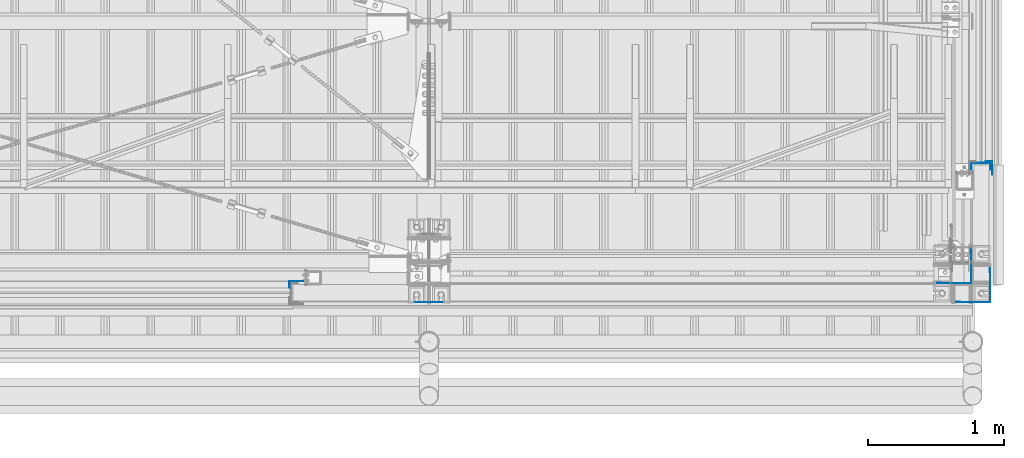
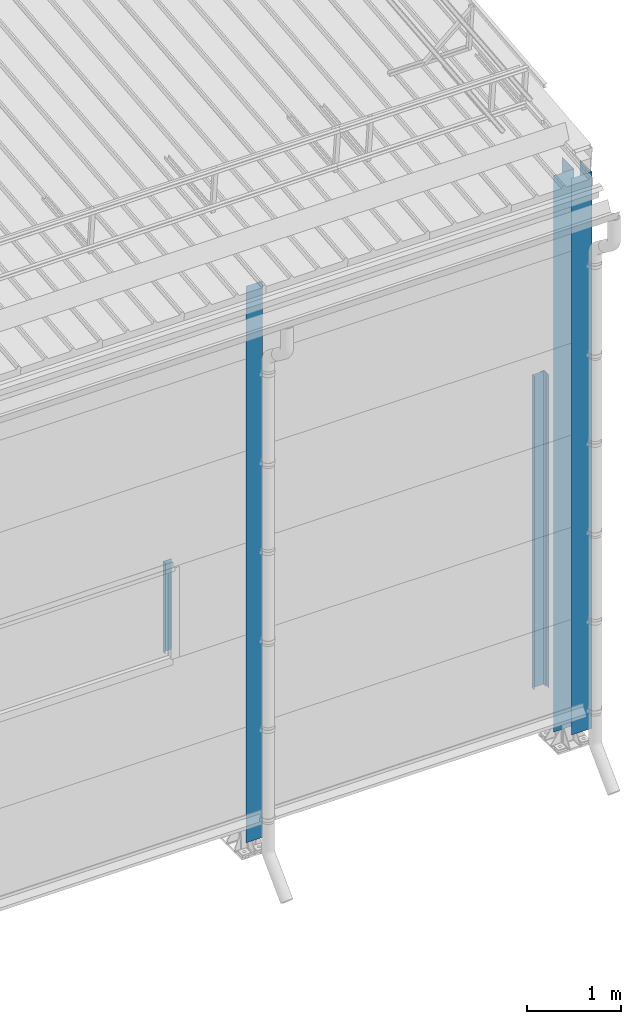
# One storey, part 12 of 709: 6 columns, 6 elements without a shape of their own.
"""IFC4 building model written with IfcOpenShell, lengths in millimetres."""

from ifc_helpers import new_model, si_unit, direction, frame, origin_with_axes, place, context, subcontext, project, spatial, line, indexed_curve, outline, extrude, material, element, aggregate, save


model = new_model("IFC4")

# Units and contexts
model_context = context("Model", 3, precision=0.2, world=origin_with_axes(), true_north=direction((0.0, 1.0)))
body_context = subcontext(model_context, "Body", "Model", "MODEL_VIEW")
ifc_project = project(units=[si_unit("LENGTHUNIT", "METRE", prefix="MILLI"), si_unit("AREAUNIT", "SQUARE_METRE"), si_unit("VOLUMEUNIT", "CUBIC_METRE"), si_unit("MASSUNIT", "GRAM", prefix="KILO"), si_unit("TIMEUNIT", "SECOND"), si_unit("PLANEANGLEUNIT", "RADIAN"), si_unit("SOLIDANGLEUNIT", "STERADIAN"), si_unit("THERMODYNAMICTEMPERATUREUNIT", "DEGREE_CELSIUS"), si_unit("LUMINOUSINTENSITYUNIT", "LUMEN")], contexts=[model_context])

# Site, building, storey
site_placement = place(None, origin_with_axes())
site = spatial("IfcSite", under=ifc_project, at=site_placement, CompositionType="ELEMENT")
building_placement = place(site_placement, origin_with_axes())
building = spatial("IfcBuilding", under=site, at=building_placement, Name="Undefined", CompositionType="ELEMENT")
storey_placement = place(building_placement, origin_with_axes())
storey = spatial("IfcBuildingStorey", under=building, at=storey_placement, Name="Undefined", CompositionType="ELEMENT", Elevation=0.0)

# Assembly, column
assembly_1_placement = place(storey_placement, frame((44975.0, 1.0, 2700.0), z_axis=(0.0, 1.0, 0.0), x_axis=(0.0, 0.0, 1.0)))
assembly_1 = element("IfcElementAssembly", 1, at=assembly_1_placement, inside=storey)
ifc_material = material(Name="Steel_Undefined", Category="STEEL")
column_1_placement = place(assembly_1_placement, origin_with_axes())
column_1 = element("IfcColumn", 2, at=column_1_placement, material=ifc_material, context=body_context, shape_type="SolidModel", body=[
    extrude(outline(indexed_curve([(-25.0, -1.0), (25.0, -1.0), (25.0, 99.0), (23.0, 99.0), (23.0, 1.0), (-25.0, 1.0)], segments=[line(1, 2, 3, 4, 5, 6, 1)])), frame((0.0, 0.0, 0.0), z_axis=(-1.0, 0.0, 0.0), x_axis=(0.0, 0.0, 1.0)), (0.0, 0.0, -1.0), 1170.0),
])
aggregate(assembly_1, [column_1])

assembly_2_placement = place(storey_placement, frame((50130.0, -130.0, 0.0), z_axis=(-1.0, 0.0, 0.0), x_axis=(0.0, 0.0, 1.0)))
assembly_2 = element("IfcElementAssembly", 3, at=assembly_2_placement, inside=storey)
column_2_placement = place(assembly_2_placement, origin_with_axes())
column_2 = element("IfcColumn", 4, at=column_2_placement, material=ifc_material, context=body_context, shape_type="SolidModel", body=[
    extrude(outline(indexed_curve([(0.0, 0.0), (250.0, 0.0), (250.0, 3.0), (220.0, 3.0), (220.0, 2.0), (249.0, 2.0), (249.0, 1.0), (1.0, 1.0), (1.0, 249.0), (2.0, 249.0), (2.0, 220.0), (3.0, 220.0), (3.0, 250.0), (0.0, 250.0)], segments=[line(1, 2, 3, 4, 5, 6, 7, 8, 9, 10, 11, 12, 13, 14, 1)])), frame((0.0, 0.0, 0.0), z_axis=(-1.0, 0.0, 0.0), x_axis=(0.0, 0.0, 1.0)), (0.0, 0.0, -1.0), 7196.92297),
])
aggregate(assembly_2, [column_2])

assembly_3_placement = place(storey_placement, frame((49990.0, 10.0, 0.0), z_axis=(-1.0, 0.0, 0.0), x_axis=(0.0, 0.0, 1.0)))
assembly_3 = element("IfcElementAssembly", 5, at=assembly_3_placement, inside=storey)
column_3_placement = place(assembly_3_placement, origin_with_axes())
column_3 = element("IfcColumn", 6, at=column_3_placement, material=ifc_material, context=body_context, shape_type="SolidModel", body=[
    extrude(outline(indexed_curve([(0.0, 0.0), (250.0, 0.0), (250.0, 3.0), (220.0, 3.0), (220.0, 2.0), (249.0, 2.0), (249.0, 1.0), (1.0, 1.0), (1.0, 249.0), (2.0, 249.0), (2.0, 220.0), (3.0, 220.0), (3.0, 250.0), (0.0, 250.0)], segments=[line(1, 2, 3, 4, 5, 6, 7, 8, 9, 10, 11, 12, 13, 14, 1)])), frame((0.0, 0.0, 0.0), z_axis=(-1.0, 0.0, 0.0), x_axis=(0.0, 0.0, 1.0)), (0.0, 0.0, -1.0), 7196.92297),
])
aggregate(assembly_3, [column_3])

assembly_4_placement = place(storey_placement, frame((46000.0, -130.0, 0.0), z_axis=(0.0, 1.0, 0.0), x_axis=(0.0, 0.0, 1.0)))
assembly_4 = element("IfcElementAssembly", 7, at=assembly_4_placement, inside=storey)
column_4_placement = place(assembly_4_placement, origin_with_axes())
column_4 = element("IfcColumn", 8, at=column_4_placement, material=ifc_material, context=body_context, shape_type="SolidModel", body=[
    extrude(outline(indexed_curve([(-0.375, -100.0), (1.245, -100.0), (1.245, -50.0), (0.495, -50.0), (0.495, -99.25), (0.375, -99.25), (0.375, 99.25), (0.495, 99.25), (0.495, 50.0), (1.245, 50.0), (1.245, 100.0), (-0.375, 100.0)], segments=[line(1, 2, 3, 4, 5, 6, 7, 8, 9, 10, 11, 12, 1)])), frame((0.0, 0.0, 0.0), z_axis=(-1.0, 0.0, 0.0), x_axis=(0.0, 0.0, 1.0)), (0.0, 0.0, -1.0), 7196.92297),
])
aggregate(assembly_4, [column_4])

assembly_5_placement = place(storey_placement, frame((50060.0, 870.0, -50.0), z_axis=(-1.0, 0.0, 0.0), x_axis=(0.0, 0.0, 1.0)))
assembly_5 = element("IfcElementAssembly", 9, at=assembly_5_placement, inside=storey)
column_5_placement = place(assembly_5_placement, origin_with_axes())
column_5 = element("IfcColumn", 10, at=column_5_placement, material=ifc_material, context=body_context, shape_type="SolidModel", body=[
    extrude(outline(indexed_curve([(-70.0, -25.0), (-68.0, -25.0), (-68.0, 23.0), (68.0, 23.0), (68.0, -25.0), (70.0, -25.0), (70.0, 25.0), (-70.0, 25.0)], segments=[line(1, 2, 3, 4, 5, 6, 7, 8, 1)])), frame((0.0, 0.0, 0.0), z_axis=(-1.0, 0.0, 0.0), x_axis=(0.0, 0.0, 1.0)), (0.0, 0.0, -1.0), 4050.0),
])
aggregate(assembly_5, [column_5])

assembly_6_placement = place(storey_placement, frame((50119.0, 905.0, -50.0), z_axis=(1.0, 0.0, 0.0), x_axis=(0.0, 0.0, 1.0)))
assembly_6 = element("IfcElementAssembly", 11, at=assembly_6_placement, inside=storey)
column_6_placement = place(assembly_6_placement, origin_with_axes())
column_6 = element("IfcColumn", 12, at=column_6_placement, material=ifc_material, context=body_context, shape_type="SolidModel", body=[
    extrude(outline(indexed_curve([(-25.0, -1.0), (25.0, -1.0), (25.0, 99.0), (23.0, 99.0), (23.0, 1.0), (-25.0, 1.0)], segments=[line(1, 2, 3, 4, 5, 6, 1)])), frame((0.0, 0.0, 0.0), z_axis=(-1.0, 0.0, 0.0), x_axis=(0.0, 0.0, 1.0)), (0.0, 0.0, -1.0), 4050.0),
])
aggregate(assembly_6, [column_6])

save(model, "model.ifc")
